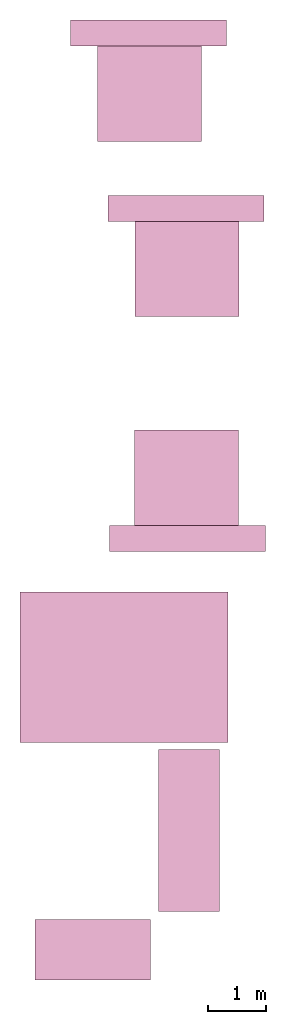
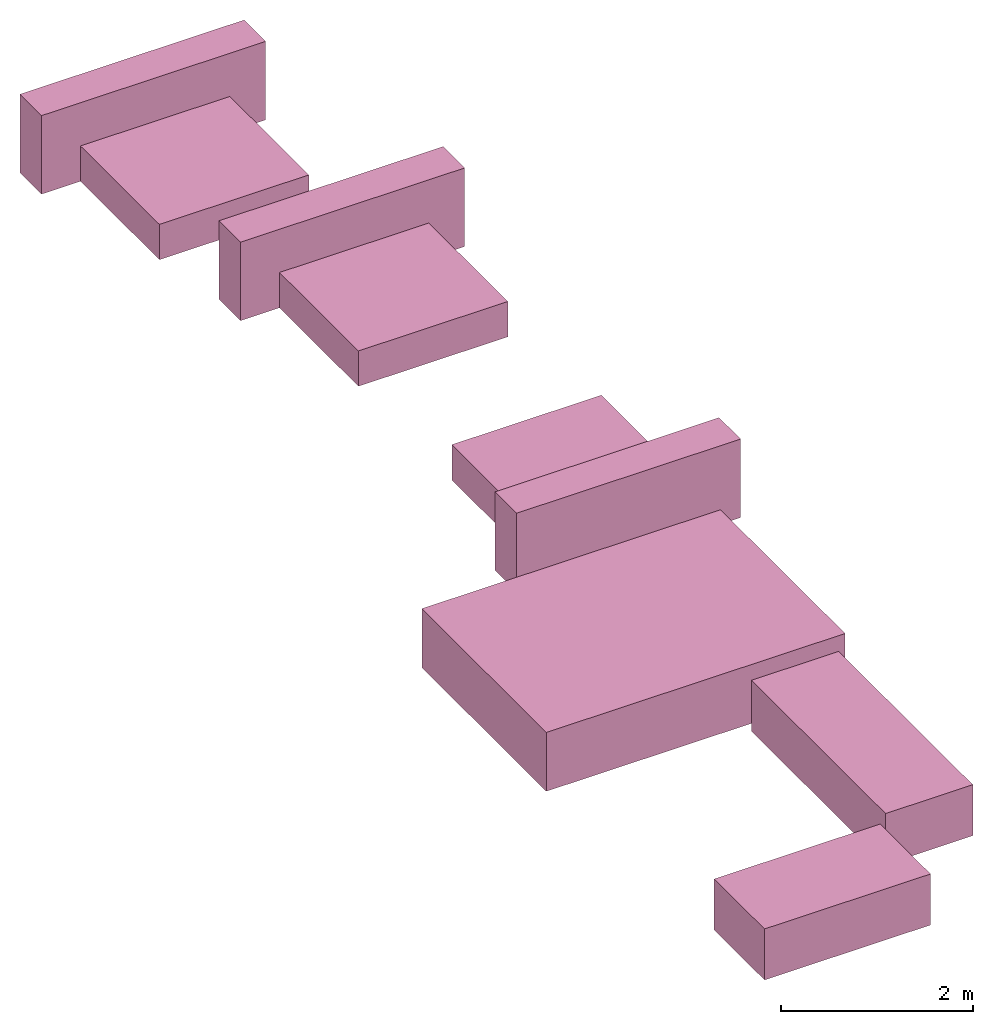
# One storey: 6 furniture elements.
"""IFC4 building model written with IfcOpenShell, lengths in millimetres."""

from ifc_helpers import new_model, entity, si_unit, converted_unit, frame, origin_with_axes, origin_2d_with_axis, place, context, subcontext, project, spatial, polygons, source, transform, mapped, type_object, type_shapes, element, save


model = new_model("IFC4")

# Units and contexts
model_context = context("Model", 3, precision=1e-05, world=origin_with_axes())
plan_context = context("Plan", 2, precision=1e-05, world=origin_2d_with_axis())
body_context = subcontext(model_context, "Body", "Model", "MODEL_VIEW")
ifc_project = project(units=[si_unit("VOLUMEUNIT", "CUBIC_METRE"), si_unit("LENGTHUNIT", "METRE", prefix="MILLI"), converted_unit("PLANEANGLEUNIT", "degree", entity("IfcReal", 0.0174532925199433), si_unit("PLANEANGLEUNIT", "RADIAN"), dimensions=[0, 0, 0, 0, 0, 0, 0]), si_unit("AREAUNIT", "SQUARE_METRE")], contexts=[model_context, plan_context])

# Site, building, storey
site_placement = place(None, origin_with_axes())
site = spatial("IfcSite", under=ifc_project, at=site_placement)
building_placement = place(site_placement, origin_with_axes())
building = spatial("IfcBuilding", under=site, at=building_placement, Name="Building")
storey_placement = place(building_placement, origin_with_axes())
storey = spatial("IfcBuildingStorey", under=building, at=storey_placement, Name="Furniture")

# Furniture
furniture_type_1 = type_object("IfcFurnitureType", Name="2 seater", AssemblyPlace="NOTDEFINED", PredefinedType="SOFA")
shared_shape_1 = source(origin_with_axes(), body_context, "Body", "Tessellation", [
    polygons([(1049.99987792969, 2000.00012207031, 649.999938964844), (1049.99987792969, 2000.00012207031, 0.0), (1049.99987792969, 0.000114087008114439, 649.999938964844), (1049.99987792969, 0.000114087008114439, 0.0), (-0.000357627839548513, 0.000114087008114439, 0.0), (-0.000357627839548513, 2000.00012207031, 649.999938964844), (-0.000357627839548513, 2000.00012207031, 0.0), (-0.000357627839548513, 0.000114087008114439, 649.999938964844)], [[[1, 6, 8, 3]], [[7, 2, 4, 5]], [[4, 3, 8, 5]], [[2, 1, 3, 4]], [[7, 6, 1, 2]], [[5, 8, 6, 7]]], closed=True),
])
type_shapes(furniture_type_1, [shared_shape_1])
furniture_1_placement = place(storey_placement, frame((5751.81770324707, 1366.0569190979, 0.0), z_axis=(0.0, 0.0, 1.0), x_axis=(-4.37113882867379e-08, 0.999999999999999, 0.0)))
element("IfcFurniture", 1, at=furniture_1_placement, inside=storey, type_object=furniture_type_1, Name="Furniture", context=body_context, shape_type="MappedRepresentation", body=[
    mapped(shared_shape_1, transform((0.0, 0.0, 0.0), x_axis=(1.0, 0.0, 0.0), y_axis=(0.0, 1.0, 0.0), z_axis=(0.0, 0.0, 1.0), scale=1.0)),
])
furniture_type_2 = type_object("IfcFurnitureType", Name="3 seater", AssemblyPlace="NOTDEFINED", PredefinedType="SOFA")
shared_shape_2 = source(origin_with_axes(), body_context, "Body", "Tessellation", [
    polygons([(1049.99987792969, 2800.0, 649.999938964844), (1049.99987792969, 2800.0, 0.0), (1049.99987792969, 0.000114087008114439, 649.999938964844), (1049.99987792969, 0.000114087008114439, 0.0), (-0.000357627839548513, 0.000114087008114439, 0.0), (-0.000357627839548513, 2800.0, 649.999938964844), (-0.000357627839548513, 2800.0, 0.0), (-0.000357627839548513, 0.000114087008114439, 649.999938964844)], [[[1, 6, 8, 3]], [[7, 2, 4, 5]], [[4, 3, 8, 5]], [[2, 1, 3, 4]], [[7, 6, 1, 2]], [[5, 8, 6, 7]]], closed=True),
])
type_shapes(furniture_type_2, [shared_shape_2])
furniture_2_placement = place(storey_placement, frame((5895.61319351196, 2552.36911773682, 0.0), z_axis=(0.0, 0.0, 1.0), x_axis=(1.0, 0.0, 0.0)))
element("IfcFurniture", 2, at=furniture_2_placement, inside=storey, type_object=furniture_type_2, Name="Furniture", context=body_context, shape_type="MappedRepresentation", body=[
    mapped(shared_shape_2, transform((0.0, 0.0, 0.0), x_axis=(1.0, 0.0, 0.0), y_axis=(0.0, 1.0, 0.0), z_axis=(0.0, 0.0, 1.0), scale=1.0)),
])
furniture_type_3 = type_object("IfcFurnitureType", Name="6", AssemblyPlace="NOTDEFINED", PredefinedType="TABLE")
shared_shape_3 = source(origin_with_axes(), body_context, "Body", "Tessellation", [
    polygons([(2599.99975585938, 3600.0, 749.999816894531), (2599.99975585938, 0.000114087000838481, 749.999816894531), (-0.000357627810444683, 3600.0, 749.999816894531), (-0.000357627810444683, 0.000114087000838481, 749.999816894531), (-0.000357627810444683, 0.000114087000838481, 0.0), (-0.000357627810444683, 3600.0, 0.0), (2599.99975585938, 3600.0, 0.0), (2599.99975585938, 0.000114087000838481, 0.0)], [[[1, 2, 8, 7]], [[3, 4, 2, 1]], [[3, 1, 7, 6]], [[4, 3, 6, 5]], [[4, 5, 8, 2]], [[8, 5, 6, 7]]], closed=True),
])
type_shapes(furniture_type_3, [shared_shape_3])
furniture_3_placement = place(storey_placement, frame((3496.1097240448, 8076.61819458008, 0.0), z_axis=(0.0, 0.0, 1.0), x_axis=(7.54979012640431e-08, -0.999999999999997, 0.0)))
element("IfcFurniture", 3, at=furniture_3_placement, inside=storey, type_object=furniture_type_3, Name="Furniture", context=body_context, shape_type="MappedRepresentation", body=[
    mapped(shared_shape_3, transform((0.0, 0.0, 0.0), x_axis=(1.0, 0.0, 0.0), y_axis=(0.0, 1.0, 0.0), z_axis=(0.0, 0.0, 1.0), scale=1.0)),
])
furniture_type_4 = type_object("IfcFurnitureType", Name="King Size", AssemblyPlace="NOTDEFINED", PredefinedType="BED")
shared_shape_4 = source(origin_with_axes(), body_context, "Body", "Tessellation", [
    polygons([(2.91689348220825, 2001.2890625, 449.999877929688), (1802.91625976562, 2001.2890625, 449.999877929688), (2.91689348220825, 2001.2890625, 0.0), (1802.91625976562, 2001.2890625, 0.0), (1802.91625976562, 1.28962075710297, 449.999877929688), (1802.91625976562, 1.28962075710297, 0.0), (2.91689348220825, 1.28962075710297, 0.0), (2.91689348220825, 1.28962075710297, 449.999877929688), (-465.363525390625, 1649.72766113281, 0.0), (-465.363525390625, 1649.72766113281, 999.999816894531), (-465.363525390625, 2099.72778320312, 0.0), (-465.363525390625, 2099.72778320312, 999.999816894531), (2234.63598632812, 2099.72778320312, 999.999816894531), (2234.63598632812, 2099.72778320312, 0.0), (2234.63598632812, 1649.72766113281, 0.0), (2234.63598632812, 1649.72766113281, 999.999816894531)], [[[2, 3, 1]], [[2, 4, 3]], [[5, 4, 2]], [[5, 6, 4]], [[3, 4, 6]], [[3, 6, 7]], [[1, 8, 2]], [[2, 8, 5]], [[6, 5, 8]], [[6, 8, 7]], [[7, 8, 1]], [[7, 1, 3]], [[9, 10, 11]], [[11, 10, 12]], [[13, 14, 11]], [[13, 11, 12]], [[13, 15, 14]], [[16, 15, 13]], [[15, 16, 10]], [[15, 10, 9]], [[11, 14, 15]], [[11, 15, 9]], [[13, 12, 16]], [[12, 10, 16]]], closed=True),
])
type_shapes(furniture_type_4, [shared_shape_4])
for number, where, z_axis, x_axis, name in (
    (4, (4832.11326599121, 15868.7782287598, 0.0), (0.0, 0.0, 1.0), (0.999999999999993, -1.1920928955078e-07, 0.0), "Furniture"),
    (5, (5479.19273376465, 12836.856842041, 0.0), (0.0, 0.0, 1.0), (0.999999999999993, -1.1920928955078e-07, 0.0), "Furniture"),
    (6, (7276.63564682007, 10875.9098052979, 0.0), (0.0, 0.0, 1.0), (-0.999999999999989, 1.50995802528085e-07, 0.0), "Furniture"),
):
    element("IfcFurniture", number, at=place(storey_placement, frame(where, z_axis=z_axis, x_axis=x_axis)), inside=storey, type_object=furniture_type_4, Name=name, context=body_context, shape_type="MappedRepresentation", body=[
        mapped(shared_shape_4, transform((0.0, 0.0, 0.0), x_axis=(1.0, 0.0, 0.0), y_axis=(0.0, 1.0, 0.0), z_axis=(0.0, 0.0, 1.0), scale=1.0)),
    ])

save(model, "model.ifc")
